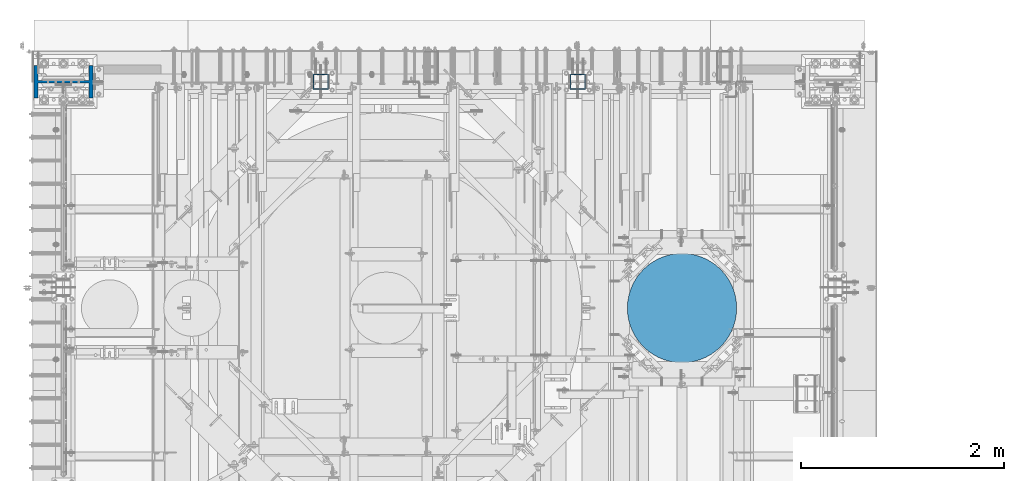
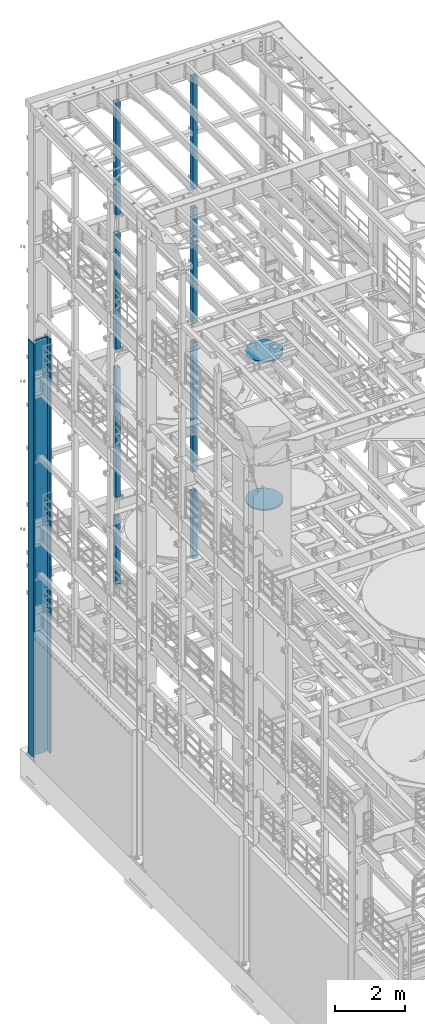
# One storey, part 751 of 1876: 11 columns, 7 elements without a shape of their own.
"""IFC2X3 building model written with IfcOpenShell, lengths in millimetres."""

from ifc_helpers import new_model, si_unit, frame, origin_with_axes, place, context, subcontext, project, spatial, faceted_brep, material, type_object, element, aggregate, save


model = new_model("IFC2X3")

# Units and contexts
model_context = context("Model", 3, precision=1e-05, world=origin_with_axes())
body_context = subcontext(model_context, "Body", "Model", "MODEL_VIEW")
ifc_project = project(units=[si_unit("LENGTHUNIT", "METRE", prefix="MILLI"), si_unit("AREAUNIT", "SQUARE_METRE"), si_unit("VOLUMEUNIT", "CUBIC_METRE"), si_unit("MASSUNIT", "GRAM", prefix="KILO"), si_unit("TIMEUNIT", "SECOND"), si_unit("PLANEANGLEUNIT", "RADIAN"), si_unit("SOLIDANGLEUNIT", "STERADIAN"), si_unit("THERMODYNAMICTEMPERATUREUNIT", "DEGREE_CELSIUS"), si_unit("LUMINOUSINTENSITYUNIT", "LUMEN")], contexts=[model_context])

# Site, building, storey
site_placement = place(None, origin_with_axes())
site = spatial("IfcSite", under=ifc_project, at=site_placement, CompositionType="ELEMENT")
building_placement = place(site_placement, origin_with_axes())
building = spatial("IfcBuilding", under=site, at=building_placement, Name="Undefined", CompositionType="ELEMENT")
storey_placement = place(building_placement, origin_with_axes())
storey = spatial("IfcBuildingStorey", under=building, at=storey_placement, Name="Undefined", CompositionType="ELEMENT", Elevation=0.0)

# Assembly, columns
assembly_1_placement = place(storey_placement, origin_with_axes())
assembly_1 = element("IfcElementAssembly", 1, at=assembly_1_placement, inside=storey, Name="FRAME", AssemblyPlace="NOTDEFINED", PredefinedType="RIGID_FRAME")
ifc_material_1 = material()
column_type_1 = type_object("IfcColumnType", Name="HSS6X6X3/8", PredefinedType="NOTDEFINED")
column_1_placement = place(assembly_1_placement, frame((5080.0, 13716.0, 17983.2), z_axis=(-1.0, 0.0, 0.0), x_axis=(0.0, 0.0, 1.0)))
column_1 = element("IfcColumn", 2, at=column_1_placement, type_object=column_type_1, material=ifc_material_1, Name="COLUMN", ObjectType="HSS6X6X3/8", context=body_context, shape_type="Brep", body=[
    faceted_brep([(12.7000000000016, 66.6750000000002, -66.6750000000002), (12.7000000000016, -66.6750000000002, -66.6750000000002), (3937.0, -66.6750000000002, -66.675), (3937.0, 66.6750000000002, -66.675), (12.7000000000016, -66.6750000000002, 66.6750000000002), (3937.0, -66.6750000000002, 66.675), (12.7000000000016, 66.6750000000002, 66.6750000000002), (3937.0, 66.6750000000002, 66.675), (12.7000000000016, 76.1999999999998, -76.1999999999998), (12.7000000000016, 76.1999999999998, 76.1999999999998), (3937.0, 76.1999999999998, 76.2), (3937.0, 76.1999999999998, -76.2), (12.7000000000016, -76.1999999999998, 76.1999999999998), (3937.0, -76.1999999999998, 76.2), (12.7000000000016, -76.1999999999998, -76.1999999999998), (3937.0, -76.1999999999998, -76.2)], [[[0, 1, 2, 3]], [[1, 4, 5, 2]], [[4, 6, 7, 5]], [[6, 0, 3, 7]], [[8, 9, 10, 11]], [[9, 12, 13, 10]], [[12, 14, 15, 13]], [[14, 8, 11, 15]], [[13, 15, 11, 10], [5, 7, 3, 2]], [[14, 12, 9, 8], [6, 4, 1, 0]]]),
])
column_2_placement = place(assembly_1_placement, frame((2540.0, 13716.0, 17983.2), z_axis=(-1.0, 0.0, 0.0), x_axis=(0.0, 0.0, 1.0)))
column_2 = element("IfcColumn", 3, at=column_2_placement, type_object=column_type_1, material=ifc_material_1, Name="COLUMN", ObjectType="HSS6X6X3/8", context=body_context, shape_type="Brep", body=[
    faceted_brep([(12.7000000000016, 66.6750000000002, -66.6750000000002), (12.7000000000016, -66.6750000000002, -66.6750000000002), (3937.0, -66.6750000000002, -66.675), (3937.0, 66.6750000000002, -66.675), (12.7000000000016, -66.6750000000002, 66.6750000000002), (3937.0, -66.6750000000002, 66.675), (12.7000000000016, 66.6750000000002, 66.6750000000002), (3937.0, 66.6750000000002, 66.675), (12.7000000000016, 76.1999999999998, -76.1999999999998), (12.7000000000016, 76.1999999999998, 76.1999999999998), (3937.0, 76.1999999999998, 76.2), (3937.0, 76.1999999999998, -76.2), (12.7000000000016, -76.1999999999998, 76.1999999999998), (3937.0, -76.1999999999998, 76.2), (12.7000000000016, -76.1999999999998, -76.1999999999998), (3937.0, -76.1999999999998, -76.2)], [[[0, 1, 2, 3]], [[1, 4, 5, 2]], [[4, 6, 7, 5]], [[6, 0, 3, 7]], [[8, 9, 10, 11]], [[9, 12, 13, 10]], [[12, 14, 15, 13]], [[14, 8, 11, 15]], [[13, 15, 11, 10], [5, 7, 3, 2]], [[14, 12, 9, 8], [6, 4, 1, 0]]]),
])
aggregate(assembly_1, [column_1, column_2])

assembly_2_placement = place(storey_placement, origin_with_axes())
assembly_2 = element("IfcElementAssembly", 4, at=assembly_2_placement, inside=storey, Name="FRAME", AssemblyPlace="NOTDEFINED", PredefinedType="RIGID_FRAME")
column_3_placement = place(assembly_2_placement, frame((5080.0, 13716.0, 13309.6), z_axis=(-1.0, 0.0, 0.0), x_axis=(0.0, 0.0, 1.0)))
column_3 = element("IfcColumn", 5, at=column_3_placement, type_object=column_type_1, material=ifc_material_1, Name="COLUMN", ObjectType="HSS6X6X3/8", context=body_context, shape_type="Brep", body=[
    faceted_brep([(12.7000000000016, 66.6750000000002, -66.6750000000002), (12.7000000000016, -66.6750000000002, -66.6750000000002), (4038.6, -66.6750000000002, -66.675), (4038.6, 66.6750000000002, -66.675), (12.7000000000016, -66.6750000000002, 66.6750000000002), (4038.6, -66.6750000000002, 66.675), (12.7000000000016, 66.6750000000002, 66.6750000000002), (4038.6, 66.6750000000002, 66.675), (12.7000000000016, 76.1999999999998, -76.1999999999998), (12.7000000000016, 76.1999999999998, 76.1999999999998), (4038.6, 76.1999999999998, 76.2), (4038.6, 76.1999999999998, -76.2), (12.7000000000016, -76.1999999999998, 76.1999999999998), (4038.6, -76.1999999999998, 76.2), (12.7000000000016, -76.1999999999998, -76.1999999999998), (4038.6, -76.1999999999998, -76.2)], [[[0, 1, 2, 3]], [[1, 4, 5, 2]], [[4, 6, 7, 5]], [[6, 0, 3, 7]], [[8, 9, 10, 11]], [[9, 12, 13, 10]], [[12, 14, 15, 13]], [[14, 8, 11, 15]], [[13, 15, 11, 10], [5, 7, 3, 2]], [[14, 12, 9, 8], [6, 4, 1, 0]]]),
])
column_4_placement = place(assembly_2_placement, frame((2540.0, 13716.0, 13309.6), z_axis=(-1.0, 0.0, 0.0), x_axis=(0.0, 0.0, 1.0)))
column_4 = element("IfcColumn", 6, at=column_4_placement, type_object=column_type_1, material=ifc_material_1, Name="COLUMN", ObjectType="HSS6X6X3/8", context=body_context, shape_type="Brep", body=[
    faceted_brep([(12.7000000000016, 66.6750000000002, -66.6750000000002), (12.7000000000016, -66.6750000000002, -66.6750000000002), (4038.6, -66.6750000000002, -66.675), (4038.6, 66.6750000000002, -66.675), (12.7000000000016, -66.6750000000002, 66.6750000000002), (4038.6, -66.6750000000002, 66.675), (12.7000000000016, 66.6750000000002, 66.6750000000002), (4038.6, 66.6750000000002, 66.675), (12.7000000000016, 76.1999999999998, -76.1999999999998), (12.7000000000016, 76.1999999999998, 76.1999999999998), (4038.6, 76.1999999999998, 76.2), (4038.6, 76.1999999999998, -76.2), (12.7000000000016, -76.1999999999998, 76.1999999999998), (4038.6, -76.1999999999998, 76.2), (12.7000000000016, -76.1999999999998, -76.1999999999998), (4038.6, -76.1999999999998, -76.2)], [[[0, 1, 2, 3]], [[1, 4, 5, 2]], [[4, 6, 7, 5]], [[6, 0, 3, 7]], [[8, 9, 10, 11]], [[9, 12, 13, 10]], [[12, 14, 15, 13]], [[14, 8, 11, 15]], [[13, 15, 11, 10], [5, 7, 3, 2]], [[14, 12, 9, 8], [6, 4, 1, 0]]]),
])
aggregate(assembly_2, [column_3, column_4])

assembly_3_placement = place(storey_placement, origin_with_axes())
assembly_3 = element("IfcElementAssembly", 7, at=assembly_3_placement, inside=storey, Name="FRAME", AssemblyPlace="NOTDEFINED", PredefinedType="RIGID_FRAME")
column_5_placement = place(assembly_3_placement, frame((5080.0, 13716.0, 8153.4), z_axis=(-1.0, 0.0, 0.0), x_axis=(0.0, 0.0, 1.0)))
column_5 = element("IfcColumn", 8, at=column_5_placement, type_object=column_type_1, material=ifc_material_1, Name="COLUMN", ObjectType="HSS6X6X3/8", context=body_context, shape_type="Brep", body=[
    faceted_brep([(12.7000000000016, 66.6750000000002, -66.6750000000002), (12.7000000000016, -66.6750000000002, -66.6750000000002), (4514.85, -66.6749999999993, -66.6750000000002), (4514.85, 66.6749999999993, -66.6750000000002), (12.7000000000016, -66.6750000000002, 66.6750000000002), (4514.85, -66.6749999999993, 66.6750000000002), (12.7000000000016, 66.6750000000002, 66.6750000000002), (4514.85, 66.6749999999993, 66.6750000000002), (12.7000000000016, 76.1999999999998, -76.1999999999998), (12.7000000000016, 76.1999999999998, 76.1999999999998), (4514.85, 76.2000000000007, 76.1999999999998), (4514.85, 76.2000000000007, -76.1999999999998), (12.7000000000016, -76.1999999999998, 76.1999999999998), (4514.85, -76.2000000000007, 76.1999999999998), (12.7000000000016, -76.1999999999998, -76.1999999999998), (4514.85, -76.2000000000007, -76.1999999999998)], [[[0, 1, 2, 3]], [[1, 4, 5, 2]], [[4, 6, 7, 5]], [[6, 0, 3, 7]], [[8, 9, 10, 11]], [[9, 12, 13, 10]], [[12, 14, 15, 13]], [[14, 8, 11, 15]], [[13, 15, 11, 10], [5, 7, 3, 2]], [[14, 12, 9, 8], [6, 4, 1, 0]]]),
])
column_6_placement = place(assembly_3_placement, frame((2540.0, 13716.0, 8153.4), z_axis=(-1.0, 0.0, 0.0), x_axis=(0.0, 0.0, 1.0)))
column_6 = element("IfcColumn", 9, at=column_6_placement, type_object=column_type_1, material=ifc_material_1, Name="COLUMN", ObjectType="HSS6X6X3/8", context=body_context, shape_type="Brep", body=[
    faceted_brep([(12.7000000000016, 66.6750000000002, -66.6750000000002), (12.7000000000016, -66.6750000000002, -66.6750000000002), (4514.85, -66.6749999999993, -66.6750000000002), (4514.85, 66.6749999999993, -66.6750000000002), (12.7000000000016, -66.6750000000002, 66.6750000000002), (4514.85, -66.6749999999993, 66.6750000000002), (12.7000000000016, 66.6750000000002, 66.6750000000002), (4514.85, 66.6749999999993, 66.6750000000002), (12.7000000000016, 76.1999999999998, -76.1999999999998), (12.7000000000016, 76.1999999999998, 76.1999999999998), (4514.85, 76.2000000000007, 76.1999999999998), (4514.85, 76.2000000000007, -76.1999999999998), (12.7000000000016, -76.1999999999998, 76.1999999999998), (4514.85, -76.2000000000007, 76.1999999999998), (12.7000000000016, -76.1999999999998, -76.1999999999998), (4514.85, -76.2000000000007, -76.1999999999998)], [[[0, 1, 2, 3]], [[1, 4, 5, 2]], [[4, 6, 7, 5]], [[6, 0, 3, 7]], [[8, 9, 10, 11]], [[9, 12, 13, 10]], [[12, 14, 15, 13]], [[14, 8, 11, 15]], [[13, 15, 11, 10], [5, 7, 3, 2]], [[14, 12, 9, 8], [6, 4, 1, 0]]]),
])
aggregate(assembly_3, [column_5, column_6])

assembly_4_placement = place(storey_placement, origin_with_axes())
assembly_4 = element("IfcElementAssembly", 10, at=assembly_4_placement, inside=storey, Name="FRAME", AssemblyPlace="NOTDEFINED", PredefinedType="RIGID_FRAME")
column_7_placement = place(assembly_4_placement, frame((5080.0, 13716.0, 5130.8), z_axis=(-1.0, 0.0, 0.0), x_axis=(0.0, 0.0, 1.0)))
column_7 = element("IfcColumn", 11, at=column_7_placement, type_object=column_type_1, material=ifc_material_1, Name="COLUMN", ObjectType="HSS6X6X3/8", context=body_context, shape_type="Brep", body=[
    faceted_brep([(12.7000000000016, 66.6750000000002, -66.6750000000002), (12.7000000000016, -66.6750000000002, -66.6750000000002), (2362.2, -66.6749999999993, -66.6750000000002), (2362.2, 66.6749999999993, -66.6750000000002), (12.7000000000016, -66.6750000000002, 66.6750000000002), (2362.2, -66.6749999999993, 66.6750000000002), (12.7000000000016, 66.6750000000002, 66.6750000000002), (2362.2, 66.6749999999993, 66.6750000000002), (12.7000000000016, 76.1999999999998, -76.1999999999998), (12.7000000000016, 76.1999999999998, 76.1999999999998), (2362.2, 76.2000000000007, 76.1999999999998), (2362.2, 76.2000000000007, -76.1999999999998), (12.7000000000016, -76.1999999999998, 76.1999999999998), (2362.2, -76.2000000000007, 76.1999999999998), (12.7000000000016, -76.1999999999998, -76.1999999999998), (2362.2, -76.2000000000007, -76.1999999999998)], [[[0, 1, 2, 3]], [[1, 4, 5, 2]], [[4, 6, 7, 5]], [[6, 0, 3, 7]], [[8, 9, 10, 11]], [[9, 12, 13, 10]], [[12, 14, 15, 13]], [[14, 8, 11, 15]], [[13, 15, 11, 10], [5, 7, 3, 2]], [[14, 12, 9, 8], [6, 4, 1, 0]]]),
])
column_8_placement = place(assembly_4_placement, frame((2540.0, 13716.0, 5130.8), z_axis=(-1.0, 0.0, 0.0), x_axis=(0.0, 0.0, 1.0)))
column_8 = element("IfcColumn", 12, at=column_8_placement, type_object=column_type_1, material=ifc_material_1, Name="COLUMN", ObjectType="HSS6X6X3/8", context=body_context, shape_type="Brep", body=[
    faceted_brep([(12.7000000000016, 66.6750000000002, -66.6750000000002), (12.7000000000016, -66.6750000000002, -66.6750000000002), (2362.2, -66.6749999999993, -66.6750000000002), (2362.2, 66.6749999999993, -66.6750000000002), (12.7000000000016, -66.6750000000002, 66.6750000000002), (2362.2, -66.6749999999993, 66.6750000000002), (12.7000000000016, 66.6750000000002, 66.6750000000002), (2362.2, 66.6749999999993, 66.6750000000002), (12.7000000000016, 76.1999999999998, -76.1999999999998), (12.7000000000016, 76.1999999999998, 76.1999999999998), (2362.2, 76.2000000000007, 76.1999999999998), (2362.2, 76.2000000000007, -76.1999999999998), (12.7000000000016, -76.1999999999998, 76.1999999999998), (2362.2, -76.2000000000007, 76.1999999999998), (12.7000000000016, -76.1999999999998, -76.1999999999998), (2362.2, -76.2000000000007, -76.1999999999998)], [[[0, 1, 2, 3]], [[1, 4, 5, 2]], [[4, 6, 7, 5]], [[6, 0, 3, 7]], [[8, 9, 10, 11]], [[9, 12, 13, 10]], [[12, 14, 15, 13]], [[14, 8, 11, 15]], [[13, 15, 11, 10], [5, 7, 3, 2]], [[14, 12, 9, 8], [6, 4, 1, 0]]]),
])
aggregate(assembly_4, [column_7, column_8])

# Assembly, column
assembly_5_placement = place(storey_placement, origin_with_axes())
assembly_5 = element("IfcElementAssembly", 13, at=assembly_5_placement, inside=storey, Name="COLUMN", AssemblyPlace="NOTDEFINED", PredefinedType="REINFORCEMENT_UNIT")
ifc_material_2 = material(Name="CONCRETE/3000")
column_type_2 = type_object("IfcColumnType", PredefinedType="NOTDEFINED")
column_9_placement = place(assembly_5_placement, frame((6108.7000000745, 11480.8000000745, 13284.2), z_axis=(-1.0, 0.0, 0.0), x_axis=(0.0, 0.0, 1.0)))
column_9 = element("IfcColumn", 14, at=column_9_placement, type_object=column_type_2, material=ifc_material_2, Name="COLUMN", context=body_context, shape_type="Brep", body=[
    faceted_brep([(0.0, -539.75, 0.0), (0.0, -536.356165289877, -60.4328259767608), (50.7999999999993, -536.356165289877, -60.4328259767608), (50.7999999999993, -539.75, 0.0), (0.0, -526.217340600138, -120.105674102921), (50.7999999999993, -526.217340600138, -120.105674102921), (0.0, -509.461027533942, -178.268123690302), (50.7999999999993, -509.461027533942, -178.268123690302), (0.0, -486.297946450331, -234.188748188702), (50.7999999999993, -486.297946450331, -234.188748188702), (0.0, -457.019386533466, -287.164313299153), (50.7999999999993, -457.019386533466, -287.164313299153), (0.0, -421.99354266212, -336.528620553251), (50.7999999999993, -421.99354266212, -336.528620553251), (0.0, -381.660885145438, -381.660885145439), (50.7999999999993, -381.660885145438, -381.660885145439), (0.0, -336.528620553252, -421.99354266212), (50.7999999999993, -336.528620553252, -421.99354266212), (0.0, -287.164313299152, -457.019386533467), (50.7999999999993, -287.164313299152, -457.019386533467), (0.0, -234.188748188702, -486.297946450331), (50.7999999999993, -234.188748188702, -486.297946450331), (0.0, -178.268123690301, -509.461027533941), (50.7999999999993, -178.268123690301, -509.461027533941), (0.0, -120.105674102921, -526.217340600139), (50.7999999999993, -120.105674102921, -526.217340600139), (0.0, -60.4328259767608, -536.356165289878), (50.7999999999993, -60.4328259767608, -536.356165289878), (0.0, 0.0, -539.75), (50.7999999999993, 0.0, -539.75), (0.0, 60.4328259767608, -536.356165289878), (50.7999999999993, 60.4328259767608, -536.356165289878), (0.0, 120.105674102921, -526.217340600139), (50.7999999999993, 120.105674102921, -526.217340600139), (0.0, 178.268123690301, -509.461027533941), (50.7999999999993, 178.268123690301, -509.461027533941), (0.0, 234.188748188702, -486.297946450331), (50.7999999999993, 234.188748188702, -486.297946450331), (0.0, 287.164313299152, -457.019386533466), (50.7999999999993, 287.164313299152, -457.019386533466), (0.0, 336.528620553252, -421.993542662119), (50.7999999999993, 336.528620553252, -421.993542662119), (0.0, 381.660885145438, -381.660885145439), (50.7999999999993, 381.660885145438, -381.660885145439), (0.0, 421.99354266212, -336.528620553251), (50.7999999999993, 421.99354266212, -336.528620553251), (0.0, 457.019386533466, -287.164313299153), (50.7999999999993, 457.019386533466, -287.164313299153), (0.0, 486.297946450331, -234.188748188702), (50.7999999999993, 486.297946450331, -234.188748188702), (0.0, 509.461027533942, -178.268123690302), (50.7999999999993, 509.461027533942, -178.268123690302), (0.0, 526.217340600138, -120.105674102921), (50.7999999999993, 526.217340600138, -120.105674102921), (0.0, 536.356165289877, -60.4328259767608), (50.7999999999993, 536.356165289877, -60.4328259767608), (0.0, 539.75, 0.0), (50.7999999999993, 539.75, 0.0), (0.0, 536.356165289877, 60.4328259767608), (50.7999999999993, 536.356165289877, 60.4328259767608), (0.0, 526.217340600138, 120.105674102921), (50.7999999999993, 526.217340600138, 120.105674102921), (0.0, 509.461027533942, 178.268123690302), (50.7999999999993, 509.461027533942, 178.268123690302), (0.0, 486.297946450331, 234.188748188702), (50.7999999999993, 486.297946450331, 234.188748188702), (0.0, 457.019386533466, 287.164313299153), (50.7999999999993, 457.019386533466, 287.164313299153), (0.0, 421.99354266212, 336.528620553251), (50.7999999999993, 421.99354266212, 336.528620553251), (0.0, 381.660885145438, 381.660885145439), (50.7999999999993, 381.660885145438, 381.660885145439), (0.0, 336.528620553252, 421.99354266212), (50.7999999999993, 336.528620553252, 421.99354266212), (0.0, 287.164313299152, 457.019386533467), (50.7999999999993, 287.164313299152, 457.019386533467), (0.0, 234.188748188702, 486.297946450331), (50.7999999999993, 234.188748188702, 486.297946450331), (0.0, 178.268123690301, 509.461027533941), (50.7999999999993, 178.268123690301, 509.461027533941), (0.0, 120.105674102921, 526.217340600139), (50.7999999999993, 120.105674102921, 526.217340600139), (0.0, 60.4328259767608, 536.356165289878), (50.7999999999993, 60.4328259767608, 536.356165289878), (0.0, 0.0, 539.75), (50.7999999999993, 0.0, 539.75), (0.0, -60.4328259767608, 536.356165289878), (50.7999999999993, -60.4328259767608, 536.356165289878), (0.0, -120.105674102921, 526.217340600139), (50.7999999999993, -120.105674102921, 526.217340600139), (0.0, -178.268123690301, 509.461027533941), (50.7999999999993, -178.268123690301, 509.461027533941), (0.0, -234.188748188702, 486.297946450331), (50.7999999999993, -234.188748188702, 486.297946450331), (0.0, -287.164313299152, 457.019386533466), (50.7999999999993, -287.164313299152, 457.019386533466), (0.0, -336.528620553252, 421.993542662119), (50.7999999999993, -336.528620553252, 421.993542662119), (0.0, -381.660885145438, 381.660885145439), (50.7999999999993, -381.660885145438, 381.660885145439), (0.0, -421.99354266212, 336.528620553251), (50.7999999999993, -421.99354266212, 336.528620553251), (0.0, -457.019386533466, 287.164313299153), (50.7999999999993, -457.019386533466, 287.164313299153), (0.0, -486.297946450331, 234.188748188702), (50.7999999999993, -486.297946450331, 234.188748188702), (0.0, -509.461027533942, 178.268123690302), (50.7999999999993, -509.461027533942, 178.268123690302), (0.0, -526.217340600138, 120.105674102921), (50.7999999999993, -526.217340600138, 120.105674102921), (0.0, -536.356165289877, 60.4328259767608), (50.7999999999993, -536.356165289877, 60.4328259767608)], [[[0, 1, 2, 3]], [[1, 4, 5, 2]], [[4, 6, 7, 5]], [[6, 8, 9, 7]], [[8, 10, 11, 9]], [[10, 12, 13, 11]], [[12, 14, 15, 13]], [[14, 16, 17, 15]], [[16, 18, 19, 17]], [[18, 20, 21, 19]], [[20, 22, 23, 21]], [[22, 24, 25, 23]], [[24, 26, 27, 25]], [[26, 28, 29, 27]], [[28, 30, 31, 29]], [[30, 32, 33, 31]], [[32, 34, 35, 33]], [[34, 36, 37, 35]], [[36, 38, 39, 37]], [[38, 40, 41, 39]], [[40, 42, 43, 41]], [[42, 44, 45, 43]], [[44, 46, 47, 45]], [[46, 48, 49, 47]], [[48, 50, 51, 49]], [[50, 52, 53, 51]], [[52, 54, 55, 53]], [[54, 56, 57, 55]], [[56, 58, 59, 57]], [[58, 60, 61, 59]], [[60, 62, 63, 61]], [[62, 64, 65, 63]], [[64, 66, 67, 65]], [[66, 68, 69, 67]], [[68, 70, 71, 69]], [[70, 72, 73, 71]], [[72, 74, 75, 73]], [[74, 76, 77, 75]], [[76, 78, 79, 77]], [[78, 80, 81, 79]], [[80, 82, 83, 81]], [[82, 84, 85, 83]], [[84, 86, 87, 85]], [[86, 88, 89, 87]], [[88, 90, 91, 89]], [[90, 92, 93, 91]], [[92, 94, 95, 93]], [[94, 96, 97, 95]], [[96, 98, 99, 97]], [[98, 100, 101, 99]], [[100, 102, 103, 101]], [[102, 104, 105, 103]], [[104, 106, 107, 105]], [[106, 108, 109, 107]], [[108, 110, 111, 109]], [[110, 0, 3, 111]], [[5, 7, 9, 11, 13, 15, 17, 19, 21, 23, 25, 27, 29, 31, 33, 35, 37, 39, 41, 43, 45, 47, 49, 51, 53, 55, 57, 59, 61, 63, 65, 67, 69, 71, 73, 75, 77, 79, 81, 83, 85, 87, 89, 91, 93, 95, 97, 99, 101, 103, 105, 107, 109, 111, 3, 2]], [[110, 108, 106, 104, 102, 100, 98, 96, 94, 92, 90, 88, 86, 84, 82, 80, 78, 76, 74, 72, 70, 68, 66, 64, 62, 60, 58, 56, 54, 52, 50, 48, 46, 44, 42, 40, 38, 36, 34, 32, 30, 28, 26, 24, 22, 20, 18, 16, 14, 12, 10, 8, 6, 4, 1, 0]]]),
])
aggregate(assembly_5, [column_9])

assembly_6_placement = place(storey_placement, origin_with_axes())
assembly_6 = element("IfcElementAssembly", 15, at=assembly_6_placement, inside=storey, Name="COLUMN", AssemblyPlace="NOTDEFINED", PredefinedType="REINFORCEMENT_UNIT")
column_10_placement = place(assembly_6_placement, frame((6108.7, 11480.8, 8128.0), z_axis=(-1.0, 0.0, 0.0), x_axis=(0.0, 0.0, 1.0)))
column_10 = element("IfcColumn", 16, at=column_10_placement, type_object=column_type_2, material=ifc_material_2, Name="COLUMN", context=body_context, shape_type="Brep", body=[
    faceted_brep([(0.0, -539.75, 0.0), (0.0, -536.356165289877, -60.4328259767608), (50.7999999999993, -536.356165289877, -60.4328259767608), (50.7999999999993, -539.75, 0.0), (0.0, -526.217340600138, -120.105674102921), (50.7999999999993, -526.217340600138, -120.105674102921), (0.0, -509.461027533942, -178.268123690302), (50.7999999999993, -509.461027533942, -178.268123690302), (0.0, -486.297946450331, -234.188748188702), (50.7999999999993, -486.297946450331, -234.188748188702), (0.0, -457.019386533466, -287.164313299153), (50.7999999999993, -457.019386533466, -287.164313299153), (0.0, -421.99354266212, -336.528620553251), (50.7999999999993, -421.99354266212, -336.528620553251), (0.0, -381.660885145438, -381.660885145439), (50.7999999999993, -381.660885145438, -381.660885145439), (0.0, -336.528620553252, -421.99354266212), (50.7999999999993, -336.528620553252, -421.99354266212), (0.0, -287.164313299152, -457.019386533467), (50.7999999999993, -287.164313299152, -457.019386533467), (0.0, -234.188748188702, -486.297946450331), (50.7999999999993, -234.188748188702, -486.297946450331), (0.0, -178.268123690301, -509.461027533941), (50.7999999999993, -178.268123690301, -509.461027533941), (0.0, -120.105674102921, -526.217340600139), (50.7999999999993, -120.105674102921, -526.217340600139), (0.0, -60.4328259767608, -536.356165289878), (50.7999999999993, -60.4328259767608, -536.356165289878), (0.0, 0.0, -539.75), (50.7999999999993, 0.0, -539.75), (0.0, 60.4328259767608, -536.356165289878), (50.7999999999993, 60.4328259767608, -536.356165289878), (0.0, 120.105674102921, -526.217340600139), (50.7999999999993, 120.105674102921, -526.217340600139), (0.0, 178.268123690301, -509.461027533941), (50.7999999999993, 178.268123690301, -509.461027533941), (0.0, 234.188748188702, -486.297946450331), (50.7999999999993, 234.188748188702, -486.297946450331), (0.0, 287.164313299152, -457.019386533466), (50.7999999999993, 287.164313299152, -457.019386533466), (0.0, 336.528620553252, -421.993542662119), (50.7999999999993, 336.528620553252, -421.993542662119), (0.0, 381.660885145438, -381.660885145439), (50.7999999999993, 381.660885145438, -381.660885145439), (0.0, 421.99354266212, -336.528620553251), (50.7999999999993, 421.99354266212, -336.528620553251), (0.0, 457.019386533466, -287.164313299153), (50.7999999999993, 457.019386533466, -287.164313299153), (0.0, 486.297946450331, -234.188748188702), (50.7999999999993, 486.297946450331, -234.188748188702), (0.0, 509.461027533942, -178.268123690302), (50.7999999999993, 509.461027533942, -178.268123690302), (0.0, 526.217340600138, -120.105674102921), (50.7999999999993, 526.217340600138, -120.105674102921), (0.0, 536.356165289877, -60.4328259767608), (50.7999999999993, 536.356165289877, -60.4328259767608), (0.0, 539.75, 0.0), (50.7999999999993, 539.75, 0.0), (0.0, 536.356165289877, 60.4328259767608), (50.7999999999993, 536.356165289877, 60.4328259767608), (0.0, 526.217340600138, 120.105674102921), (50.7999999999993, 526.217340600138, 120.105674102921), (0.0, 509.461027533942, 178.268123690302), (50.7999999999993, 509.461027533942, 178.268123690302), (0.0, 486.297946450331, 234.188748188702), (50.7999999999993, 486.297946450331, 234.188748188702), (0.0, 457.019386533466, 287.164313299153), (50.7999999999993, 457.019386533466, 287.164313299153), (0.0, 421.99354266212, 336.528620553251), (50.7999999999993, 421.99354266212, 336.528620553251), (0.0, 381.660885145438, 381.660885145439), (50.7999999999993, 381.660885145438, 381.660885145439), (0.0, 336.528620553252, 421.99354266212), (50.7999999999993, 336.528620553252, 421.99354266212), (0.0, 287.164313299152, 457.019386533467), (50.7999999999993, 287.164313299152, 457.019386533467), (0.0, 234.188748188702, 486.297946450331), (50.7999999999993, 234.188748188702, 486.297946450331), (0.0, 178.268123690301, 509.461027533941), (50.7999999999993, 178.268123690301, 509.461027533941), (0.0, 120.105674102921, 526.217340600139), (50.7999999999993, 120.105674102921, 526.217340600139), (0.0, 60.4328259767608, 536.356165289878), (50.7999999999993, 60.4328259767608, 536.356165289878), (0.0, 0.0, 539.75), (50.7999999999993, 0.0, 539.75), (0.0, -60.4328259767608, 536.356165289878), (50.7999999999993, -60.4328259767608, 536.356165289878), (0.0, -120.105674102921, 526.217340600139), (50.7999999999993, -120.105674102921, 526.217340600139), (0.0, -178.268123690301, 509.461027533941), (50.7999999999993, -178.268123690301, 509.461027533941), (0.0, -234.188748188702, 486.297946450331), (50.7999999999993, -234.188748188702, 486.297946450331), (0.0, -287.164313299152, 457.019386533466), (50.7999999999993, -287.164313299152, 457.019386533466), (0.0, -336.528620553252, 421.993542662119), (50.7999999999993, -336.528620553252, 421.993542662119), (0.0, -381.660885145438, 381.660885145439), (50.7999999999993, -381.660885145438, 381.660885145439), (0.0, -421.99354266212, 336.528620553251), (50.7999999999993, -421.99354266212, 336.528620553251), (0.0, -457.019386533466, 287.164313299153), (50.7999999999993, -457.019386533466, 287.164313299153), (0.0, -486.297946450331, 234.188748188702), (50.7999999999993, -486.297946450331, 234.188748188702), (0.0, -509.461027533942, 178.268123690302), (50.7999999999993, -509.461027533942, 178.268123690302), (0.0, -526.217340600138, 120.105674102921), (50.7999999999993, -526.217340600138, 120.105674102921), (0.0, -536.356165289877, 60.4328259767608), (50.7999999999993, -536.356165289877, 60.4328259767608)], [[[0, 1, 2, 3]], [[1, 4, 5, 2]], [[4, 6, 7, 5]], [[6, 8, 9, 7]], [[8, 10, 11, 9]], [[10, 12, 13, 11]], [[12, 14, 15, 13]], [[14, 16, 17, 15]], [[16, 18, 19, 17]], [[18, 20, 21, 19]], [[20, 22, 23, 21]], [[22, 24, 25, 23]], [[24, 26, 27, 25]], [[26, 28, 29, 27]], [[28, 30, 31, 29]], [[30, 32, 33, 31]], [[32, 34, 35, 33]], [[34, 36, 37, 35]], [[36, 38, 39, 37]], [[38, 40, 41, 39]], [[40, 42, 43, 41]], [[42, 44, 45, 43]], [[44, 46, 47, 45]], [[46, 48, 49, 47]], [[48, 50, 51, 49]], [[50, 52, 53, 51]], [[52, 54, 55, 53]], [[54, 56, 57, 55]], [[56, 58, 59, 57]], [[58, 60, 61, 59]], [[60, 62, 63, 61]], [[62, 64, 65, 63]], [[64, 66, 67, 65]], [[66, 68, 69, 67]], [[68, 70, 71, 69]], [[70, 72, 73, 71]], [[72, 74, 75, 73]], [[74, 76, 77, 75]], [[76, 78, 79, 77]], [[78, 80, 81, 79]], [[80, 82, 83, 81]], [[82, 84, 85, 83]], [[84, 86, 87, 85]], [[86, 88, 89, 87]], [[88, 90, 91, 89]], [[90, 92, 93, 91]], [[92, 94, 95, 93]], [[94, 96, 97, 95]], [[96, 98, 99, 97]], [[98, 100, 101, 99]], [[100, 102, 103, 101]], [[102, 104, 105, 103]], [[104, 106, 107, 105]], [[106, 108, 109, 107]], [[108, 110, 111, 109]], [[110, 0, 3, 111]], [[5, 7, 9, 11, 13, 15, 17, 19, 21, 23, 25, 27, 29, 31, 33, 35, 37, 39, 41, 43, 45, 47, 49, 51, 53, 55, 57, 59, 61, 63, 65, 67, 69, 71, 73, 75, 77, 79, 81, 83, 85, 87, 89, 91, 93, 95, 97, 99, 101, 103, 105, 107, 109, 111, 3, 2]], [[110, 108, 106, 104, 102, 100, 98, 96, 94, 92, 90, 88, 86, 84, 82, 80, 78, 76, 74, 72, 70, 68, 66, 64, 62, 60, 58, 56, 54, 52, 50, 48, 46, 44, 42, 40, 38, 36, 34, 32, 30, 28, 26, 24, 22, 20, 18, 16, 14, 12, 10, 8, 6, 4, 1, 0]]]),
])
aggregate(assembly_6, [column_10])

assembly_7_placement = place(storey_placement, origin_with_axes())
assembly_7 = element("IfcElementAssembly", 17, at=assembly_7_placement, inside=storey, Name="COLUMN", AssemblyPlace="NOTDEFINED", PredefinedType="RIGID_FRAME")
ifc_material_3 = material(Name="STEEL/A992")
column_type_3 = type_object("IfcColumnType", Name="W21X201", PredefinedType="NOTDEFINED")
column_11_placement = place(assembly_7_placement, frame((0.0, 13716.0, 0.0), z_axis=(-1.0, 0.0, 0.0), x_axis=(0.0, 0.0, 1.0)))
column_11 = element("IfcColumn", 18, at=column_11_placement, type_object=column_type_3, material=ifc_material_3, Name="COLUMN", ObjectType="W21X201", context=body_context, shape_type="Brep", body=[
    faceted_brep([(112.712499999999, 11.90625, 200.025000762939), (112.712499999999, 11.90625, -200.025000762939), (88.9, -11.90625, -200.025000762939), (88.9, -11.90625, 200.025000762939), (14528.8, -160.3375, 292.1), (14528.8, 160.3375, 292.1), (130.174999999997, 160.3375, 292.1), (130.175, -160.3375, 292.099999999999), (139.700000000013, -160.3375, 250.825), (14478.0, -160.3375, 250.825), (14528.8, -160.3375, 250.825), (88.9, -160.3375, 250.825), (139.700000000013, -11.90625, 250.825), (14478.0, -11.90625, 250.825), (14528.8, -11.90625, 250.825), (88.9, -11.90625, 250.825), (14528.8, -160.3375, -292.1), (14528.8, -160.3375, -250.825), (14478.0000007629, -160.3375, -250.825), (139.700000000013, -160.3375, -250.825), (88.9, -160.3375, -250.825), (130.175000825646, -160.3375, -292.100000825653), (14528.8, 160.3375, -292.1), (130.175000825646, 160.3375, -292.1), (139.700000000013, 160.3375, -250.825), (14478.0000007629, 160.3375, -250.825), (14528.8, 160.3375, -250.825), (88.9, 160.3375, -250.825), (14528.8, 11.90625, -250.825), (14528.8, -11.90625, -250.825), (14478.0000007629, -11.90625, -250.825), (139.700000000013, -11.90625, -250.825), (88.9, -11.90625, -250.825), (114.300000381483, -11.90625, -200.025000762939), (114.300000381483, 11.90625, -200.025000762939), (124.020159417574, 11.90625, -201.958460608115), (124.020159417574, -11.90625, -201.958460608115), (132.260512353882, 11.90625, -207.464488409071), (132.260512353882, -11.90625, -207.464488409071), (137.766540154838, 11.90625, -215.704841345379), (137.766540154838, -11.90625, -215.704841345379), (139.700000000013, 11.90625, -225.42500038147), (139.700000000013, -11.90625, -225.42500038147), (139.700000000013, 11.90625, -250.825), (88.9, 11.90625, -250.825), (14478.0000007629, 11.90625, -250.825), (14481.8669204533, 11.90625, -231.384681927819), (14481.8669204533, -11.90625, -231.384681927819), (14492.8789760552, 11.90625, -214.903976055204), (14492.8789760552, -11.90625, -214.903976055204), (14509.3596819278, 11.90625, -203.891920453291), (14509.3596819278, -11.90625, -203.891920453291), (14528.8, -11.90625, -200.02500076294), (14528.8, 11.90625, -200.02500076294), (14528.8, 11.90625, 200.02500076294), (14528.8, -11.90625, 200.02500076294), (14509.3596811649, 11.90625, 203.891920453291), (14509.3596811649, -11.90625, 203.891920453291), (14492.8789752923, 11.90625, 214.903976055204), (14492.8789752923, -11.90625, 214.903976055204), (14481.8669196904, 11.90625, 231.384681927819), (14481.8669196904, -11.90625, 231.384681927819), (14478.0, 11.90625, 250.825), (14528.8, 11.90625, 250.825), (14528.8, 160.3375, 250.825), (14478.0, 160.3375, 250.825), (139.700000000013, 160.3375, 250.825), (88.9, 160.3375, 250.825), (88.9, 11.90625, 250.825), (139.700000000013, 11.90625, 250.825), (139.700000000013, 11.90625, 225.42500038147), (139.700000000013, -11.90625, 225.42500038147), (137.766540154838, 11.90625, 215.704841345379), (137.766540154838, -11.90625, 215.704841345379), (132.260512353882, 11.90625, 207.464488409071), (132.260512353882, -11.90625, 207.464488409071), (124.020159417574, 11.90625, 201.958460608115), (124.020159417574, -11.90625, 201.958460608115), (114.300000381483, 11.90625, 200.025000762939), (114.300000381483, -11.90625, 200.025000762939)], [[[0, 1, 2, 3]], [[4, 5, 6, 7]], [[8, 9, 10, 4, 7, 11]], [[12, 13, 14, 10, 9, 8, 11, 15]], [[16, 17, 18, 19, 20, 21]], [[22, 16, 21, 23]], [[24, 25, 26, 22, 23, 27]], [[17, 16, 22, 26, 28, 29]], [[19, 18, 17, 29, 30, 31, 32, 20]], [[33, 34, 35, 36]], [[36, 35, 37, 38]], [[38, 37, 39, 40]], [[40, 39, 41, 42]], [[42, 41, 43, 31]], [[31, 43, 44, 32]], [[27, 23, 21, 20, 32, 44]], [[43, 45, 28, 26, 25, 24, 27, 44]], [[29, 28, 45, 30]], [[30, 45, 46, 47]], [[47, 46, 48, 49]], [[49, 48, 50, 51]], [[52, 51, 50, 53]], [[54, 55, 52, 53]], [[55, 54, 56, 57]], [[57, 56, 58, 59]], [[59, 58, 60, 61]], [[61, 60, 62, 13]], [[14, 13, 62, 63]], [[64, 5, 4, 10, 14, 63]], [[5, 64, 65, 66, 67, 6]], [[11, 7, 6, 67, 68, 15]], [[66, 65, 64, 63, 62, 69, 68, 67]], [[15, 68, 69, 12]], [[12, 69, 70, 71]], [[71, 70, 72, 73]], [[73, 72, 74, 75]], [[75, 74, 76, 77]], [[77, 76, 78, 79]], [[79, 78, 0, 3]], [[33, 36, 38, 40, 42, 31, 30, 47, 49, 51, 52, 55, 57, 59, 61, 13, 12, 71, 73, 75, 77, 79, 3, 2]], [[34, 33, 2, 1]], [[78, 76, 74, 72, 70, 69, 62, 60, 58, 56, 54, 53, 50, 48, 46, 45, 43, 41, 39, 37, 35, 34, 1, 0]]]),
])
aggregate(assembly_7, [column_11])

save(model, "model.ifc")
